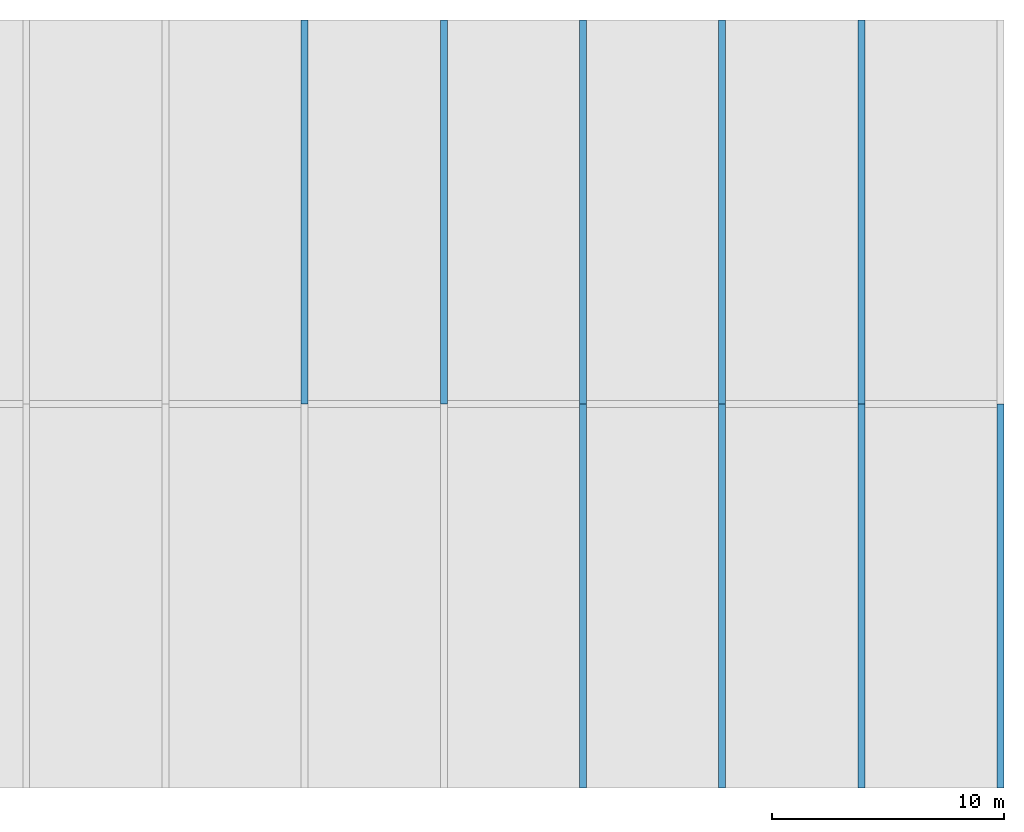
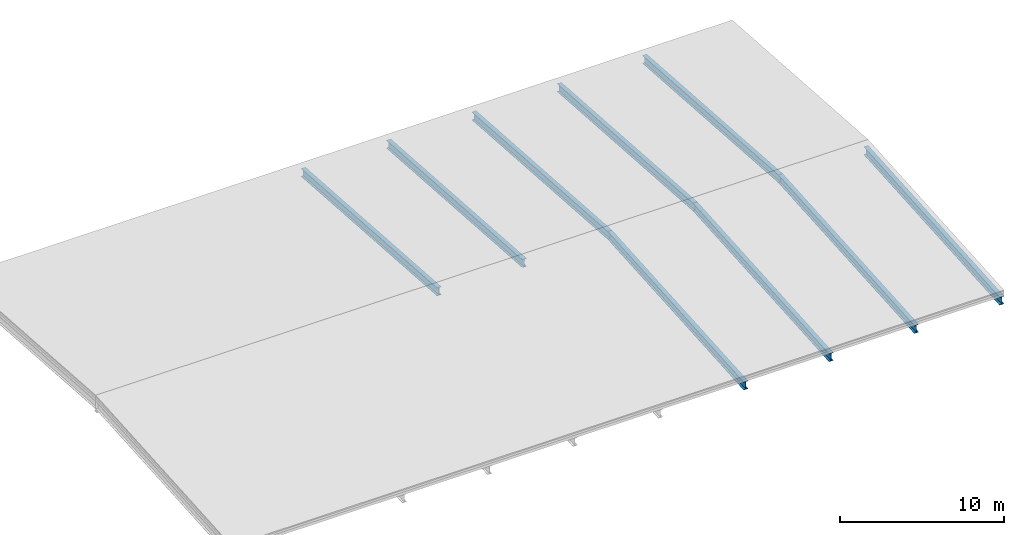
# One storey, part 2 of 3: 9 beams.
"""IFC2X3 building model written with IfcOpenShell, lengths in millimetres."""

from ifc_helpers import new_model, entity, si_unit, converted_unit, frame, origin, place, context, subcontext, project, spatial, faceted_brep, material, element, save


model = new_model("IFC2X3")

# Units and contexts
model_context = context("Model", 3, precision=1e-05, world=origin())
body_context = subcontext(model_context, "Body", "Model", "MODEL_VIEW")
ifc_project = project(units=[si_unit("LENGTHUNIT", "METRE", prefix="MILLI"), converted_unit("PLANEANGLEUNIT", "DEGREE", entity("IfcPlaneAngleMeasure", 0.0174532925199433), si_unit("PLANEANGLEUNIT", "RADIAN"), dimensions=[0, 0, 0, 0, 0, 0, 0]), si_unit("AREAUNIT", "SQUARE_METRE"), si_unit("VOLUMEUNIT", "CUBIC_METRE")], contexts=[model_context])

# Building, storey
building_placement = place(None, origin())
building = spatial("IfcBuilding", under=ifc_project, at=building_placement, CompositionType="ELEMENT")
storey_placement = place(building_placement, frame((0.0, 0.0, 7000.0), z_axis=(0.0, 0.0, 1.0), x_axis=(1.0, 0.0, 0.0)))
storey = spatial("IfcBuildingStorey", under=building, at=storey_placement, Name="Dach", CompositionType="ELEMENT", Elevation=7000.0)

# Beams
ifc_material_1 = material(Name="Stahl")
beam_1_placement = place(storey_placement, frame((41979.99999999991, 16699.99999999999, -17.48170298587684), z_axis=(0.0, 0.0, 1.0), x_axis=(5.275618813909437e-15, -1.0, 0.0)))
element("IfcBeam", 1, at=beam_1_placement, inside=storey, material=ifc_material_1, context=body_context, shape_type="Brep", body=[
    faceted_brep([(16549.99999999999, 0.0, 600.0000000000009), (16549.99999999999, 0.0, 570.0000000000009), (0.0, 0.0, 1727.288737665102), (0.0, 0.0, 1757.288737665102), (16549.99999999999, 0.0, 30.0), (16549.99999999999, 0.0, 0.0), (0.0, 0.0, 1157.2887376651), (0.0, 0.0, 1187.2887376651), (16549.99999999999, 300.0, 600.0000000000009), (16549.99999999999, 300.0, 570.0000000000009), (16549.99999999999, 157.75, 570.0000000000009), (16549.99999999999, 157.75, 30.0), (16549.99999999999, 300.0, 30.0), (16549.99999999999, 300.0, 0.0), (16549.99999999999, 0.0, 0.0), (16549.99999999999, 0.0, 30.0), (16549.99999999999, 142.25, 30.0), (16549.99999999999, 142.25, 570.0000000000009), (16549.99999999999, 0.0, 570.0000000000009), (16549.99999999999, 0.0, 600.0000000000009), (0.0, 300.0, 1187.2887376651), (0.0, 300.0, 1157.2887376651), (16549.99999999999, 300.0, 0.0), (16549.99999999999, 300.0, 30.0), (0.0, 300.0, 1757.288737665102), (0.0, 300.0, 1727.288737665102), (16549.99999999999, 300.0, 570.0000000000009), (16549.99999999999, 300.0, 600.0000000000009), (0.0, 0.0, 1757.288737665102), (0.0, 0.0, 1727.288737665102), (0.0, 142.25, 1727.288737665102), (0.0, 142.25, 1187.2887376651), (0.0, 0.0, 1187.2887376651), (0.0, 0.0, 1157.2887376651), (0.0, 300.0, 1157.2887376651), (0.0, 300.0, 1187.2887376651), (0.0, 157.75, 1187.2887376651), (0.0, 157.75, 1727.288737665102), (0.0, 300.0, 1727.288737665102), (0.0, 300.0, 1757.288737665102), (16549.99999999999, 300.0, 600.0000000000009), (16549.99999999999, 0.0, 600.0000000000009), (0.0, 0.0, 1757.288737665102), (0.0, 300.0, 1757.288737665102), (16549.99999999999, 0.0, 570.0000000000009), (16549.99999999999, 142.25, 570.0000000000009), (0.0, 142.25, 1727.288737665102), (0.0, 0.0, 1727.288737665102), (16549.99999999999, 142.25, 570.0000000000009), (16549.99999999999, 142.25, 30.0), (0.0, 142.25, 1187.2887376651), (0.0, 142.25, 1727.288737665102), (16549.99999999999, 142.25, 30.0), (16549.99999999999, 0.0, 30.0), (0.0, 0.0, 1187.2887376651), (0.0, 142.25, 1187.2887376651), (16549.99999999999, 0.0, 0.0), (16549.99999999999, 300.0, 0.0), (0.0, 300.0, 1157.2887376651), (0.0, 0.0, 1157.2887376651), (16549.99999999999, 300.0, 30.0), (16549.99999999999, 157.75, 30.0), (0.0, 157.75, 1187.2887376651), (0.0, 300.0, 1187.2887376651), (16549.99999999999, 157.75, 30.0), (16549.99999999999, 157.75, 570.0000000000009), (0.0, 157.75, 1727.288737665102), (0.0, 157.75, 1187.2887376651), (16549.99999999999, 157.75, 570.0000000000009), (16549.99999999999, 300.0, 570.0000000000009), (0.0, 300.0, 1727.288737665102), (0.0, 157.75, 1727.288737665102)], [[[0, 1, 2, 3]], [[4, 5, 6, 7]], [[8, 9, 10, 11, 12, 13, 14, 15, 16, 17, 18, 19]], [[20, 21, 22, 23]], [[24, 25, 26, 27]], [[28, 29, 30, 31, 32, 33, 34, 35, 36, 37, 38, 39]], [[40, 41, 42, 43]], [[44, 45, 46, 47]], [[48, 49, 50, 51]], [[52, 53, 54, 55]], [[56, 57, 58, 59]], [[60, 61, 62, 63]], [[64, 65, 66, 67]], [[68, 69, 70, 71]]], orient=[[False], [False], [False], [False], [False], [False], [False], [False], [False], [False], [False], [False], [False], [False]]),
])
ifc_material_2 = material(Name="Stahl")
beam_2_placement = place(storey_placement, frame((41980.0, 33250.0, -17.48170298587866), z_axis=(0.0, 0.0, 1.0), x_axis=(-5.27561881390943e-15, -1.0, 0.0)))
element("IfcBeam", 2, at=beam_2_placement, inside=storey, material=ifc_material_2, context=body_context, shape_type="Brep", body=[
    faceted_brep([(16550.00000000001, 0.0, 1757.288737665103), (16550.00000000001, 0.0, 1727.288737665102), (0.0, 0.0, 570.0), (0.0, 0.0, 600.0), (16550.00000000001, 0.0, 1187.288737665102), (16550.00000000001, 0.0, 1157.288737665102), (0.0, 0.0, 0.0), (0.0, -7.275957614183426e-12, 30.0), (16550.00000000001, 300.0, 1757.288737665103), (16550.00000000001, 300.0, 1727.288737665102), (16550.00000000001, 157.75, 1727.288737665102), (16550.00000000001, 157.75, 1187.288737665102), (16550.00000000001, 300.0, 1187.288737665102), (16550.00000000001, 300.0, 1157.288737665102), (16550.00000000001, 0.0, 1157.288737665102), (16550.00000000001, 0.0, 1187.288737665102), (16550.00000000001, 142.25, 1187.288737665102), (16550.00000000001, 142.25, 1727.288737665102), (16550.00000000001, 0.0, 1727.288737665102), (16550.00000000001, 0.0, 1757.288737665103), (-7.275957614183426e-12, 300.0, 30.0), (-7.275957614183426e-12, 300.0, 0.0), (16550.00000000001, 300.0, 1157.288737665102), (16550.00000000001, 300.0, 1187.288737665102), (-7.275957614183426e-12, 300.0, 600.0), (-7.275957614183426e-12, 300.0, 570.0), (16550.00000000001, 300.0, 1727.288737665102), (16550.00000000001, 300.0, 1757.288737665103), (0.0, 0.0, 600.0), (0.0, 0.0, 570.0), (-7.275957614183426e-12, 142.2500000000073, 570.0), (-7.275957614183426e-12, 142.2500000000073, 30.0), (0.0, -7.275957614183426e-12, 30.0), (0.0, 0.0, 0.0), (-7.275957614183426e-12, 300.0, 0.0), (-7.275957614183426e-12, 300.0, 30.0), (-7.275957614183426e-12, 157.75, 30.0), (-7.275957614183426e-12, 157.75, 570.0), (-7.275957614183426e-12, 300.0, 570.0), (-7.275957614183426e-12, 300.0, 600.0), (16550.00000000001, 300.0, 1757.288737665103), (16550.00000000001, 0.0, 1757.288737665103), (0.0, 0.0, 600.0), (-7.275957614183426e-12, 300.0, 600.0), (16550.00000000001, 0.0, 1727.288737665102), (16550.00000000001, 142.25, 1727.288737665102), (-7.275957614183426e-12, 142.2500000000073, 570.0), (0.0, 0.0, 570.0), (16550.00000000001, 142.25, 1727.288737665102), (16550.00000000001, 142.25, 1187.288737665102), (-7.275957614183426e-12, 142.2500000000073, 30.0), (-7.275957614183426e-12, 142.2500000000073, 570.0), (16550.00000000001, 142.25, 1187.288737665102), (16550.00000000001, 0.0, 1187.288737665102), (0.0, -7.275957614183426e-12, 30.0), (-7.275957614183426e-12, 142.2500000000073, 30.0), (16550.00000000001, 0.0, 1157.288737665102), (16550.00000000001, 300.0, 1157.288737665102), (-7.275957614183426e-12, 300.0, 0.0), (0.0, 0.0, 0.0), (16550.00000000001, 300.0, 1187.288737665102), (16550.00000000001, 157.75, 1187.288737665102), (-7.275957614183426e-12, 157.75, 30.0), (-7.275957614183426e-12, 300.0, 30.0), (16550.00000000001, 157.75, 1187.288737665102), (16550.00000000001, 157.75, 1727.288737665102), (-7.275957614183426e-12, 157.75, 570.0), (-7.275957614183426e-12, 157.75, 30.0), (16550.00000000001, 157.75, 1727.288737665102), (16550.00000000001, 300.0, 1727.288737665102), (-7.275957614183426e-12, 300.0, 570.0), (-7.275957614183426e-12, 157.75, 570.0)], [[[0, 1, 2, 3]], [[4, 5, 6, 7]], [[8, 9, 10, 11, 12, 13, 14, 15, 16, 17, 18, 19]], [[20, 21, 22, 23]], [[24, 25, 26, 27]], [[28, 29, 30, 31, 32, 33, 34, 35, 36, 37, 38, 39]], [[40, 41, 42, 43]], [[44, 45, 46, 47]], [[48, 49, 50, 51]], [[52, 53, 54, 55]], [[56, 57, 58, 59]], [[60, 61, 62, 63]], [[64, 65, 66, 67]], [[68, 69, 70, 71]]], orient=[[False], [False], [False], [False], [False], [False], [False], [False], [False], [False], [False], [False], [False], [False]]),
])
ifc_material_3 = material(Name="Stahl")
beam_3_placement = place(storey_placement, frame((35979.99999999991, 16699.99999999999, -17.48170298587684), z_axis=(0.0, 0.0, 1.0), x_axis=(5.275618813909437e-15, -1.0, 0.0)))
element("IfcBeam", 3, at=beam_3_placement, inside=storey, material=ifc_material_3, context=body_context, shape_type="Brep", body=[
    faceted_brep([(16549.99999999999, 0.0, 600.0000000000009), (16549.99999999999, 0.0, 570.0000000000009), (0.0, 0.0, 1727.288737665102), (0.0, 0.0, 1757.288737665102), (16549.99999999999, 0.0, 30.0), (16549.99999999999, 0.0, 0.0), (0.0, 0.0, 1157.2887376651), (0.0, 0.0, 1187.2887376651), (16549.99999999999, 300.0, 600.0000000000009), (16549.99999999999, 300.0, 570.0000000000009), (16549.99999999999, 157.75, 570.0000000000009), (16549.99999999999, 157.75, 30.0), (16549.99999999999, 300.0, 30.0), (16549.99999999999, 300.0, 0.0), (16549.99999999999, 0.0, 0.0), (16549.99999999999, 0.0, 30.0), (16549.99999999999, 142.25, 30.0), (16549.99999999999, 142.25, 570.0000000000009), (16549.99999999999, 0.0, 570.0000000000009), (16549.99999999999, 0.0, 600.0000000000009), (3.637978807091713e-12, 300.0, 1187.2887376651), (3.637978807091713e-12, 300.0, 1157.2887376651), (16549.99999999999, 300.0, 0.0), (16549.99999999999, 300.0, 30.0), (3.637978807091713e-12, 300.0, 1757.288737665102), (3.637978807091713e-12, 300.0, 1727.288737665102), (16549.99999999999, 300.0, 570.0000000000009), (16549.99999999999, 300.0, 600.0000000000009), (0.0, 0.0, 1757.288737665102), (0.0, 0.0, 1727.288737665102), (0.0, 142.25, 1727.288737665102), (0.0, 142.25, 1187.2887376651), (0.0, 0.0, 1187.2887376651), (0.0, 0.0, 1157.2887376651), (3.637978807091713e-12, 300.0, 1157.2887376651), (3.637978807091713e-12, 300.0, 1187.2887376651), (0.0, 157.75, 1187.2887376651), (0.0, 157.75, 1727.288737665102), (3.637978807091713e-12, 300.0, 1727.288737665102), (3.637978807091713e-12, 300.0, 1757.288737665102), (16549.99999999999, 300.0, 600.0000000000009), (16549.99999999999, 0.0, 600.0000000000009), (0.0, 0.0, 1757.288737665102), (3.637978807091713e-12, 300.0, 1757.288737665102), (16549.99999999999, 0.0, 570.0000000000009), (16549.99999999999, 142.25, 570.0000000000009), (0.0, 142.25, 1727.288737665102), (0.0, 0.0, 1727.288737665102), (16549.99999999999, 142.25, 570.0000000000009), (16549.99999999999, 142.25, 30.0), (0.0, 142.25, 1187.2887376651), (0.0, 142.25, 1727.288737665102), (16549.99999999999, 142.25, 30.0), (16549.99999999999, 0.0, 30.0), (0.0, 0.0, 1187.2887376651), (0.0, 142.25, 1187.2887376651), (16549.99999999999, 0.0, 0.0), (16549.99999999999, 300.0, 0.0), (3.637978807091713e-12, 300.0, 1157.2887376651), (0.0, 0.0, 1157.2887376651), (16549.99999999999, 300.0, 30.0), (16549.99999999999, 157.75, 30.0), (0.0, 157.75, 1187.2887376651), (3.637978807091713e-12, 300.0, 1187.2887376651), (16549.99999999999, 157.75, 30.0), (16549.99999999999, 157.75, 570.0000000000009), (0.0, 157.75, 1727.288737665102), (0.0, 157.75, 1187.2887376651), (16549.99999999999, 157.75, 570.0000000000009), (16549.99999999999, 300.0, 570.0000000000009), (3.637978807091713e-12, 300.0, 1727.288737665102), (0.0, 157.75, 1727.288737665102)], [[[0, 1, 2, 3]], [[4, 5, 6, 7]], [[8, 9, 10, 11, 12, 13, 14, 15, 16, 17, 18, 19]], [[20, 21, 22, 23]], [[24, 25, 26, 27]], [[28, 29, 30, 31, 32, 33, 34, 35, 36, 37, 38, 39]], [[40, 41, 42, 43]], [[44, 45, 46, 47]], [[48, 49, 50, 51]], [[52, 53, 54, 55]], [[56, 57, 58, 59]], [[60, 61, 62, 63]], [[64, 65, 66, 67]], [[68, 69, 70, 71]]], orient=[[False], [False], [False], [False], [False], [False], [False], [False], [False], [False], [False], [False], [False], [False]]),
])
ifc_material_4 = material(Name="Stahl")
beam_4_placement = place(storey_placement, frame((35980.0, 33250.0, -17.48170298587866), z_axis=(0.0, 0.0, 1.0), x_axis=(-5.27561881390943e-15, -1.0, 0.0)))
element("IfcBeam", 4, at=beam_4_placement, inside=storey, material=ifc_material_4, context=body_context, shape_type="Brep", body=[
    faceted_brep([(16550.00000000001, 0.0, 1757.288737665103), (16550.00000000001, 0.0, 1727.288737665102), (0.0, 0.0, 570.0), (0.0, 0.0, 600.0), (16550.00000000001, 0.0, 1187.288737665102), (16550.00000000001, 0.0, 1157.288737665102), (0.0, 0.0, 0.0), (0.0, 0.0, 30.0), (16550.00000000001, 300.0, 1757.288737665103), (16550.00000000001, 300.0, 1727.288737665102), (16550.00000000001, 157.75, 1727.288737665102), (16550.00000000001, 157.75, 1187.288737665102), (16550.00000000001, 300.0, 1187.288737665102), (16550.00000000001, 300.0, 1157.288737665102), (16550.00000000001, 0.0, 1157.288737665102), (16550.00000000001, 0.0, 1187.288737665102), (16550.00000000001, 142.25, 1187.288737665102), (16550.00000000001, 142.25, 1727.288737665102), (16550.00000000001, 0.0, 1727.288737665102), (16550.00000000001, 0.0, 1757.288737665103), (0.0, 300.0, 30.0), (0.0, 300.0, 0.0), (16550.00000000001, 300.0, 1157.288737665102), (16550.00000000001, 300.0, 1187.288737665102), (0.0, 300.0, 600.0), (0.0, 300.0, 570.0), (16550.00000000001, 300.0, 1727.288737665102), (16550.00000000001, 300.0, 1757.288737665103), (0.0, 0.0, 600.0), (0.0, 0.0, 570.0), (0.0, 142.2500000000073, 570.0), (0.0, 142.2500000000073, 30.0), (0.0, 0.0, 30.0), (0.0, 0.0, 0.0), (0.0, 300.0, 0.0), (0.0, 300.0, 30.0), (0.0, 157.75, 30.0), (0.0, 157.75, 570.0), (0.0, 300.0, 570.0), (0.0, 300.0, 600.0), (16550.00000000001, 300.0, 1757.288737665103), (16550.00000000001, 0.0, 1757.288737665103), (0.0, 0.0, 600.0), (0.0, 300.0, 600.0), (16550.00000000001, 0.0, 1727.288737665102), (16550.00000000001, 142.25, 1727.288737665102), (0.0, 142.2500000000073, 570.0), (0.0, 0.0, 570.0), (16550.00000000001, 142.25, 1727.288737665102), (16550.00000000001, 142.25, 1187.288737665102), (0.0, 142.2500000000073, 30.0), (0.0, 142.2500000000073, 570.0), (16550.00000000001, 142.25, 1187.288737665102), (16550.00000000001, 0.0, 1187.288737665102), (0.0, 0.0, 30.0), (0.0, 142.2500000000073, 30.0), (16550.00000000001, 0.0, 1157.288737665102), (16550.00000000001, 300.0, 1157.288737665102), (0.0, 300.0, 0.0), (0.0, 0.0, 0.0), (16550.00000000001, 300.0, 1187.288737665102), (16550.00000000001, 157.75, 1187.288737665102), (0.0, 157.75, 30.0), (0.0, 300.0, 30.0), (16550.00000000001, 157.75, 1187.288737665102), (16550.00000000001, 157.75, 1727.288737665102), (0.0, 157.75, 570.0), (0.0, 157.75, 30.0), (16550.00000000001, 157.75, 1727.288737665102), (16550.00000000001, 300.0, 1727.288737665102), (0.0, 300.0, 570.0), (0.0, 157.75, 570.0)], [[[0, 1, 2, 3]], [[4, 5, 6, 7]], [[8, 9, 10, 11, 12, 13, 14, 15, 16, 17, 18, 19]], [[20, 21, 22, 23]], [[24, 25, 26, 27]], [[28, 29, 30, 31, 32, 33, 34, 35, 36, 37, 38, 39]], [[40, 41, 42, 43]], [[44, 45, 46, 47]], [[48, 49, 50, 51]], [[52, 53, 54, 55]], [[56, 57, 58, 59]], [[60, 61, 62, 63]], [[64, 65, 66, 67]], [[68, 69, 70, 71]]], orient=[[False], [False], [False], [False], [False], [False], [False], [False], [False], [False], [False], [False], [False], [False]]),
])
ifc_material_5 = material(Name="Stahl")
beam_5_placement = place(storey_placement, frame((29980.0, 33250.0, -17.48170298587866), z_axis=(0.0, 0.0, 1.0), x_axis=(-5.27561881390943e-15, -1.0, 0.0)))
element("IfcBeam", 5, at=beam_5_placement, inside=storey, material=ifc_material_5, context=body_context, shape_type="Brep", body=[
    faceted_brep([(16550.00000000002, 0.0, 1757.288737665103), (16550.00000000002, 0.0, 1727.288737665102), (0.0, 0.0, 570.0), (0.0, 0.0, 600.0), (16550.00000000002, 0.0, 1187.288737665102), (16550.00000000002, 0.0, 1157.288737665102), (0.0, 0.0, 0.0), (0.0, 0.0, 30.0), (16550.00000000001, 300.0, 1757.288737665103), (16550.00000000001, 300.0, 1727.288737665102), (16550.00000000001, 157.75, 1727.288737665102), (16550.00000000001, 157.75, 1187.288737665102), (16550.00000000001, 300.0, 1187.288737665102), (16550.00000000001, 300.0, 1157.288737665102), (16550.00000000002, 0.0, 1157.288737665102), (16550.00000000002, 0.0, 1187.288737665102), (16550.00000000001, 142.25, 1187.288737665102), (16550.00000000001, 142.25, 1727.288737665102), (16550.00000000002, 0.0, 1727.288737665102), (16550.00000000002, 0.0, 1757.288737665103), (0.0, 300.0, 30.0), (0.0, 300.0, 0.0), (16550.00000000001, 300.0, 1157.288737665102), (16550.00000000001, 300.0, 1187.288737665102), (0.0, 300.0, 600.0), (0.0, 300.0, 570.0), (16550.00000000001, 300.0, 1727.288737665102), (16550.00000000001, 300.0, 1757.288737665103), (0.0, 0.0, 600.0), (0.0, 0.0, 570.0), (0.0, 142.25, 570.0), (0.0, 142.25, 30.0), (0.0, 0.0, 30.0), (0.0, 0.0, 0.0), (0.0, 300.0, 0.0), (0.0, 300.0, 30.0), (0.0, 157.75, 30.0), (0.0, 157.75, 570.0), (0.0, 300.0, 570.0), (0.0, 300.0, 600.0), (16550.00000000001, 300.0, 1757.288737665103), (16550.00000000002, 0.0, 1757.288737665103), (0.0, 0.0, 600.0), (0.0, 300.0, 600.0), (16550.00000000002, 0.0, 1727.288737665102), (16550.00000000001, 142.25, 1727.288737665102), (0.0, 142.25, 570.0), (0.0, 0.0, 570.0), (16550.00000000001, 142.25, 1727.288737665102), (16550.00000000001, 142.25, 1187.288737665102), (0.0, 142.25, 30.0), (0.0, 142.25, 570.0), (16550.00000000001, 142.25, 1187.288737665102), (16550.00000000002, 0.0, 1187.288737665102), (0.0, 0.0, 30.0), (0.0, 142.25, 30.0), (16550.00000000002, 0.0, 1157.288737665102), (16550.00000000001, 300.0, 1157.288737665102), (0.0, 300.0, 0.0), (0.0, 0.0, 0.0), (16550.00000000001, 300.0, 1187.288737665102), (16550.00000000001, 157.75, 1187.288737665102), (0.0, 157.75, 30.0), (0.0, 300.0, 30.0), (16550.00000000001, 157.75, 1187.288737665102), (16550.00000000001, 157.75, 1727.288737665102), (0.0, 157.75, 570.0), (0.0, 157.75, 30.0), (16550.00000000001, 157.75, 1727.288737665102), (16550.00000000001, 300.0, 1727.288737665102), (0.0, 300.0, 570.0), (0.0, 157.75, 570.0)], [[[0, 1, 2, 3]], [[4, 5, 6, 7]], [[8, 9, 10, 11, 12, 13, 14, 15, 16, 17, 18, 19]], [[20, 21, 22, 23]], [[24, 25, 26, 27]], [[28, 29, 30, 31, 32, 33, 34, 35, 36, 37, 38, 39]], [[40, 41, 42, 43]], [[44, 45, 46, 47]], [[48, 49, 50, 51]], [[52, 53, 54, 55]], [[56, 57, 58, 59]], [[60, 61, 62, 63]], [[64, 65, 66, 67]], [[68, 69, 70, 71]]], orient=[[False], [False], [False], [False], [False], [False], [False], [False], [False], [False], [False], [False], [False], [False]]),
])
ifc_material_6 = material(Name="Stahl")
beam_6_placement = place(storey_placement, frame((23980.0, 33250.0, -17.48170298587866), z_axis=(0.0, 0.0, 1.0), x_axis=(-5.27561881390943e-15, -1.0, 0.0)))
element("IfcBeam", 6, at=beam_6_placement, inside=storey, material=ifc_material_6, context=body_context, shape_type="Brep", body=[
    faceted_brep([(16550.00000000001, 0.0, 1757.288737665103), (16550.00000000001, 0.0, 1727.288737665102), (0.0, 0.0, 570.0), (0.0, 0.0, 600.0), (16550.00000000001, 0.0, 1187.288737665102), (16550.00000000001, 0.0, 1157.288737665102), (0.0, 0.0, 0.0), (0.0, 0.0, 30.0), (16550.00000000001, 300.0, 1757.288737665103), (16550.00000000001, 300.0, 1727.288737665102), (16550.00000000001, 157.75, 1727.288737665102), (16550.00000000001, 157.75, 1187.288737665102), (16550.00000000001, 300.0, 1187.288737665102), (16550.00000000001, 300.0, 1157.288737665102), (16550.00000000001, 0.0, 1157.288737665102), (16550.00000000001, 0.0, 1187.288737665102), (16550.00000000001, 142.25, 1187.288737665102), (16550.00000000001, 142.25, 1727.288737665102), (16550.00000000001, 0.0, 1727.288737665102), (16550.00000000001, 0.0, 1757.288737665103), (-7.275957614183426e-12, 300.0, 30.0), (-7.275957614183426e-12, 300.0, 0.0), (16550.00000000001, 300.0, 1157.288737665102), (16550.00000000001, 300.0, 1187.288737665102), (-7.275957614183426e-12, 300.0, 600.0), (-7.275957614183426e-12, 300.0, 570.0), (16550.00000000001, 300.0, 1727.288737665102), (16550.00000000001, 300.0, 1757.288737665103), (0.0, 0.0, 600.0), (0.0, 0.0, 570.0), (0.0, 142.25, 570.0), (0.0, 142.25, 30.0), (0.0, 0.0, 30.0), (0.0, 0.0, 0.0), (-7.275957614183426e-12, 300.0, 0.0), (-7.275957614183426e-12, 300.0, 30.0), (-7.275957614183426e-12, 157.75, 30.0), (-7.275957614183426e-12, 157.75, 570.0), (-7.275957614183426e-12, 300.0, 570.0), (-7.275957614183426e-12, 300.0, 600.0), (16550.00000000001, 300.0, 1757.288737665103), (16550.00000000001, 0.0, 1757.288737665103), (0.0, 0.0, 600.0), (-7.275957614183426e-12, 300.0, 600.0), (16550.00000000001, 0.0, 1727.288737665102), (16550.00000000001, 142.25, 1727.288737665102), (0.0, 142.25, 570.0), (0.0, 0.0, 570.0), (16550.00000000001, 142.25, 1727.288737665102), (16550.00000000001, 142.25, 1187.288737665102), (0.0, 142.25, 30.0), (0.0, 142.25, 570.0), (16550.00000000001, 142.25, 1187.288737665102), (16550.00000000001, 0.0, 1187.288737665102), (0.0, 0.0, 30.0), (0.0, 142.25, 30.0), (16550.00000000001, 0.0, 1157.288737665102), (16550.00000000001, 300.0, 1157.288737665102), (-7.275957614183426e-12, 300.0, 0.0), (0.0, 0.0, 0.0), (16550.00000000001, 300.0, 1187.288737665102), (16550.00000000001, 157.75, 1187.288737665102), (-7.275957614183426e-12, 157.75, 30.0), (-7.275957614183426e-12, 300.0, 30.0), (16550.00000000001, 157.75, 1187.288737665102), (16550.00000000001, 157.75, 1727.288737665102), (-7.275957614183426e-12, 157.75, 570.0), (-7.275957614183426e-12, 157.75, 30.0), (16550.00000000001, 157.75, 1727.288737665102), (16550.00000000001, 300.0, 1727.288737665102), (-7.275957614183426e-12, 300.0, 570.0), (-7.275957614183426e-12, 157.75, 570.0)], [[[0, 1, 2, 3]], [[4, 5, 6, 7]], [[8, 9, 10, 11, 12, 13, 14, 15, 16, 17, 18, 19]], [[20, 21, 22, 23]], [[24, 25, 26, 27]], [[28, 29, 30, 31, 32, 33, 34, 35, 36, 37, 38, 39]], [[40, 41, 42, 43]], [[44, 45, 46, 47]], [[48, 49, 50, 51]], [[52, 53, 54, 55]], [[56, 57, 58, 59]], [[60, 61, 62, 63]], [[64, 65, 66, 67]], [[68, 69, 70, 71]]], orient=[[False], [False], [False], [False], [False], [False], [False], [False], [False], [False], [False], [False], [False], [False]]),
])
ifc_material_7 = material(Name="Stahl")
beam_7_placement = place(storey_placement, frame((53979.99999999991, 16699.99999999999, -17.48170298587684), z_axis=(0.0, 0.0, 1.0), x_axis=(5.275618813909437e-15, -1.0, 0.0)))
element("IfcBeam", 7, at=beam_7_placement, inside=storey, material=ifc_material_7, context=body_context, shape_type="Brep", body=[
    faceted_brep([(16549.99999999999, 0.0, 600.0000000000009), (16549.99999999999, 0.0, 570.0000000000009), (0.0, 0.0, 1727.288737665102), (0.0, 0.0, 1757.288737665102), (16549.99999999999, 0.0, 30.0), (16549.99999999999, 0.0, 0.0), (0.0, 0.0, 1157.2887376651), (0.0, 0.0, 1187.2887376651), (16549.99999999999, 300.0, 600.0000000000009), (16549.99999999999, 300.0, 570.0000000000009), (16549.99999999999, 157.75, 570.0000000000009), (16549.99999999999, 157.75, 30.0), (16549.99999999999, 300.0, 30.0), (16549.99999999999, 300.0, 0.0), (16549.99999999999, 0.0, 0.0), (16549.99999999999, 0.0, 30.0), (16549.99999999999, 142.25, 30.0), (16549.99999999999, 142.25, 570.0000000000009), (16549.99999999999, 0.0, 570.0000000000009), (16549.99999999999, 0.0, 600.0000000000009), (3.637978807091713e-12, 300.0, 1187.2887376651), (3.637978807091713e-12, 300.0, 1157.2887376651), (16549.99999999999, 300.0, 0.0), (16549.99999999999, 300.0, 30.0), (3.637978807091713e-12, 300.0, 1757.288737665102), (3.637978807091713e-12, 300.0, 1727.288737665102), (16549.99999999999, 300.0, 570.0000000000009), (16549.99999999999, 300.0, 600.0000000000009), (0.0, 0.0, 1757.288737665102), (0.0, 0.0, 1727.288737665102), (0.0, 142.25, 1727.288737665102), (0.0, 142.25, 1187.2887376651), (0.0, 0.0, 1187.2887376651), (0.0, 0.0, 1157.2887376651), (3.637978807091713e-12, 300.0, 1157.2887376651), (3.637978807091713e-12, 300.0, 1187.2887376651), (3.637978807091713e-12, 157.75, 1187.2887376651), (3.637978807091713e-12, 157.75, 1727.288737665102), (3.637978807091713e-12, 300.0, 1727.288737665102), (3.637978807091713e-12, 300.0, 1757.288737665102), (16549.99999999999, 300.0, 600.0000000000009), (16549.99999999999, 0.0, 600.0000000000009), (0.0, 0.0, 1757.288737665102), (3.637978807091713e-12, 300.0, 1757.288737665102), (16549.99999999999, 0.0, 570.0000000000009), (16549.99999999999, 142.25, 570.0000000000009), (0.0, 142.25, 1727.288737665102), (0.0, 0.0, 1727.288737665102), (16549.99999999999, 142.25, 570.0000000000009), (16549.99999999999, 142.25, 30.0), (0.0, 142.25, 1187.2887376651), (0.0, 142.25, 1727.288737665102), (16549.99999999999, 142.25, 30.0), (16549.99999999999, 0.0, 30.0), (0.0, 0.0, 1187.2887376651), (0.0, 142.25, 1187.2887376651), (16549.99999999999, 0.0, 0.0), (16549.99999999999, 300.0, 0.0), (3.637978807091713e-12, 300.0, 1157.2887376651), (0.0, 0.0, 1157.2887376651), (16549.99999999999, 300.0, 30.0), (16549.99999999999, 157.75, 30.0), (3.637978807091713e-12, 157.75, 1187.2887376651), (3.637978807091713e-12, 300.0, 1187.2887376651), (16549.99999999999, 157.75, 30.0), (16549.99999999999, 157.75, 570.0000000000009), (3.637978807091713e-12, 157.75, 1727.288737665102), (3.637978807091713e-12, 157.75, 1187.2887376651), (16549.99999999999, 157.75, 570.0000000000009), (16549.99999999999, 300.0, 570.0000000000009), (3.637978807091713e-12, 300.0, 1727.288737665102), (3.637978807091713e-12, 157.75, 1727.288737665102)], [[[0, 1, 2, 3]], [[4, 5, 6, 7]], [[8, 9, 10, 11, 12, 13, 14, 15, 16, 17, 18, 19]], [[20, 21, 22, 23]], [[24, 25, 26, 27]], [[28, 29, 30, 31, 32, 33, 34, 35, 36, 37, 38, 39]], [[40, 41, 42, 43]], [[44, 45, 46, 47]], [[48, 49, 50, 51]], [[52, 53, 54, 55]], [[56, 57, 58, 59]], [[60, 61, 62, 63]], [[64, 65, 66, 67]], [[68, 69, 70, 71]]], orient=[[False], [False], [False], [False], [False], [False], [False], [False], [False], [False], [False], [False], [False], [False]]),
])
ifc_material_8 = material(Name="Stahl")
beam_8_placement = place(storey_placement, frame((47980.0, 33250.0, -17.48170298587866), z_axis=(0.0, 0.0, 1.0), x_axis=(-5.27561881390943e-15, -1.0, 0.0)))
element("IfcBeam", 8, at=beam_8_placement, inside=storey, material=ifc_material_8, context=body_context, shape_type="Brep", body=[
    faceted_brep([(16550.00000000001, 0.0, 1757.288737665103), (16550.00000000001, 0.0, 1727.288737665102), (0.0, 0.0, 570.0), (0.0, 0.0, 600.0), (16550.00000000001, 0.0, 1187.288737665102), (16550.00000000001, 0.0, 1157.288737665102), (0.0, 0.0, 0.0), (0.0, -7.275957614183426e-12, 30.0), (16550.00000000001, 300.0, 1757.288737665103), (16550.00000000001, 300.0, 1727.288737665102), (16550.00000000001, 157.75, 1727.288737665102), (16550.00000000001, 157.75, 1187.288737665102), (16550.00000000001, 300.0, 1187.288737665102), (16550.00000000001, 300.0, 1157.288737665102), (16550.00000000001, 0.0, 1157.288737665102), (16550.00000000001, 0.0, 1187.288737665102), (16550.00000000001, 142.25, 1187.288737665102), (16550.00000000001, 142.25, 1727.288737665102), (16550.00000000001, 0.0, 1727.288737665102), (16550.00000000001, 0.0, 1757.288737665103), (0.0, 300.0, 30.0), (0.0, 300.0, 0.0), (16550.00000000001, 300.0, 1157.288737665102), (16550.00000000001, 300.0, 1187.288737665102), (0.0, 300.0, 600.0), (0.0, 300.0, 570.0), (16550.00000000001, 300.0, 1727.288737665102), (16550.00000000001, 300.0, 1757.288737665103), (0.0, 0.0, 600.0), (0.0, 0.0, 570.0), (0.0, 142.25, 570.0), (0.0, 142.25, 30.0), (0.0, -7.275957614183426e-12, 30.0), (0.0, 0.0, 0.0), (0.0, 300.0, 0.0), (0.0, 300.0, 30.0), (0.0, 157.75, 30.0), (0.0, 157.75, 570.0), (0.0, 300.0, 570.0), (0.0, 300.0, 600.0), (16550.00000000001, 300.0, 1757.288737665103), (16550.00000000001, 0.0, 1757.288737665103), (0.0, 0.0, 600.0), (0.0, 300.0, 600.0), (16550.00000000001, 0.0, 1727.288737665102), (16550.00000000001, 142.25, 1727.288737665102), (0.0, 142.25, 570.0), (0.0, 0.0, 570.0), (16550.00000000001, 142.25, 1727.288737665102), (16550.00000000001, 142.25, 1187.288737665102), (0.0, 142.25, 30.0), (0.0, 142.25, 570.0), (16550.00000000001, 142.25, 1187.288737665102), (16550.00000000001, 0.0, 1187.288737665102), (0.0, -7.275957614183426e-12, 30.0), (0.0, 142.25, 30.0), (16550.00000000001, 0.0, 1157.288737665102), (16550.00000000001, 300.0, 1157.288737665102), (0.0, 300.0, 0.0), (0.0, 0.0, 0.0), (16550.00000000001, 300.0, 1187.288737665102), (16550.00000000001, 157.75, 1187.288737665102), (0.0, 157.75, 30.0), (0.0, 300.0, 30.0), (16550.00000000001, 157.75, 1187.288737665102), (16550.00000000001, 157.75, 1727.288737665102), (0.0, 157.75, 570.0), (0.0, 157.75, 30.0), (16550.00000000001, 157.75, 1727.288737665102), (16550.00000000001, 300.0, 1727.288737665102), (0.0, 300.0, 570.0), (0.0, 157.75, 570.0)], [[[0, 1, 2, 3]], [[4, 5, 6, 7]], [[8, 9, 10, 11, 12, 13, 14, 15, 16, 17, 18, 19]], [[20, 21, 22, 23]], [[24, 25, 26, 27]], [[28, 29, 30, 31, 32, 33, 34, 35, 36, 37, 38, 39]], [[40, 41, 42, 43]], [[44, 45, 46, 47]], [[48, 49, 50, 51]], [[52, 53, 54, 55]], [[56, 57, 58, 59]], [[60, 61, 62, 63]], [[64, 65, 66, 67]], [[68, 69, 70, 71]]], orient=[[False], [False], [False], [False], [False], [False], [False], [False], [False], [False], [False], [False], [False], [False]]),
])
ifc_material_9 = material(Name="Stahl")
beam_9_placement = place(storey_placement, frame((47979.99999999991, 16699.99999999999, -17.48170298587684), z_axis=(0.0, 0.0, 1.0), x_axis=(5.275618813909437e-15, -1.0, 0.0)))
element("IfcBeam", 9, at=beam_9_placement, inside=storey, material=ifc_material_9, context=body_context, shape_type="Brep", body=[
    faceted_brep([(16549.99999999999, 0.0, 600.0000000000009), (16549.99999999999, 0.0, 570.0000000000009), (0.0, 0.0, 1727.288737665102), (0.0, 0.0, 1757.288737665102), (16549.99999999999, 0.0, 30.0), (16549.99999999999, 0.0, 0.0), (0.0, 0.0, 1157.2887376651), (0.0, 0.0, 1187.2887376651), (16549.99999999999, 300.0, 600.0000000000009), (16549.99999999999, 300.0, 570.0000000000009), (16549.99999999999, 157.75, 570.0000000000009), (16549.99999999999, 157.75, 30.0), (16549.99999999999, 300.0, 30.0), (16549.99999999999, 300.0, 0.0), (16549.99999999999, 0.0, 0.0), (16549.99999999999, 0.0, 30.0), (16549.99999999999, 142.25, 30.0), (16549.99999999999, 142.25, 570.0000000000009), (16549.99999999999, 0.0, 570.0000000000009), (16549.99999999999, 0.0, 600.0000000000009), (0.0, 300.0, 1187.2887376651), (0.0, 300.0, 1157.2887376651), (16549.99999999999, 300.0, 0.0), (16549.99999999999, 300.0, 30.0), (0.0, 300.0, 1757.288737665102), (0.0, 300.0, 1727.288737665102), (16549.99999999999, 300.0, 570.0000000000009), (16549.99999999999, 300.0, 600.0000000000009), (0.0, 0.0, 1757.288737665102), (0.0, 0.0, 1727.288737665102), (0.0, 142.25, 1727.288737665102), (0.0, 142.25, 1187.2887376651), (0.0, 0.0, 1187.2887376651), (0.0, 0.0, 1157.2887376651), (0.0, 300.0, 1157.2887376651), (0.0, 300.0, 1187.2887376651), (0.0, 157.75, 1187.2887376651), (0.0, 157.75, 1727.288737665102), (0.0, 300.0, 1727.288737665102), (0.0, 300.0, 1757.288737665102), (16549.99999999999, 300.0, 600.0000000000009), (16549.99999999999, 0.0, 600.0000000000009), (0.0, 0.0, 1757.288737665102), (0.0, 300.0, 1757.288737665102), (16549.99999999999, 0.0, 570.0000000000009), (16549.99999999999, 142.25, 570.0000000000009), (0.0, 142.25, 1727.288737665102), (0.0, 0.0, 1727.288737665102), (16549.99999999999, 142.25, 570.0000000000009), (16549.99999999999, 142.25, 30.0), (0.0, 142.25, 1187.2887376651), (0.0, 142.25, 1727.288737665102), (16549.99999999999, 142.25, 30.0), (16549.99999999999, 0.0, 30.0), (0.0, 0.0, 1187.2887376651), (0.0, 142.25, 1187.2887376651), (16549.99999999999, 0.0, 0.0), (16549.99999999999, 300.0, 0.0), (0.0, 300.0, 1157.2887376651), (0.0, 0.0, 1157.2887376651), (16549.99999999999, 300.0, 30.0), (16549.99999999999, 157.75, 30.0), (0.0, 157.75, 1187.2887376651), (0.0, 300.0, 1187.2887376651), (16549.99999999999, 157.75, 30.0), (16549.99999999999, 157.75, 570.0000000000009), (0.0, 157.75, 1727.288737665102), (0.0, 157.75, 1187.2887376651), (16549.99999999999, 157.75, 570.0000000000009), (16549.99999999999, 300.0, 570.0000000000009), (0.0, 300.0, 1727.288737665102), (0.0, 157.75, 1727.288737665102)], [[[0, 1, 2, 3]], [[4, 5, 6, 7]], [[8, 9, 10, 11, 12, 13, 14, 15, 16, 17, 18, 19]], [[20, 21, 22, 23]], [[24, 25, 26, 27]], [[28, 29, 30, 31, 32, 33, 34, 35, 36, 37, 38, 39]], [[40, 41, 42, 43]], [[44, 45, 46, 47]], [[48, 49, 50, 51]], [[52, 53, 54, 55]], [[56, 57, 58, 59]], [[60, 61, 62, 63]], [[64, 65, 66, 67]], [[68, 69, 70, 71]]], orient=[[False], [False], [False], [False], [False], [False], [False], [False], [False], [False], [False], [False], [False], [False]]),
])

save(model, "model.ifc")
